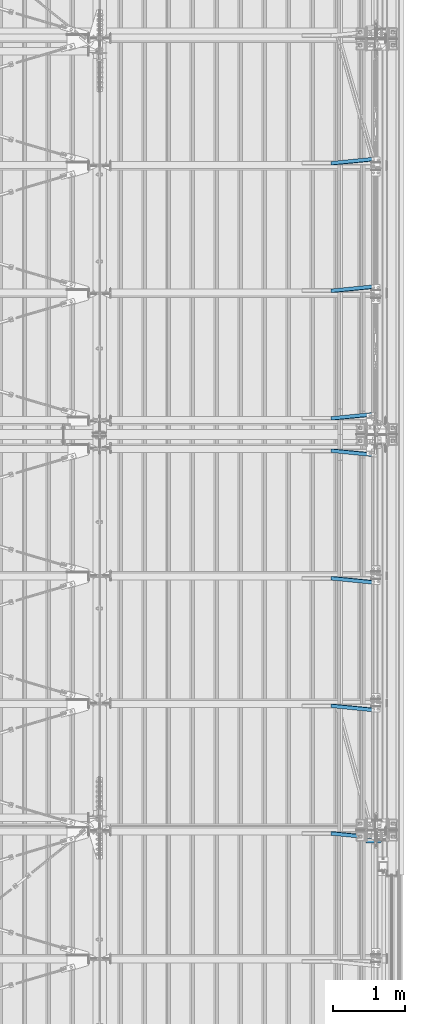
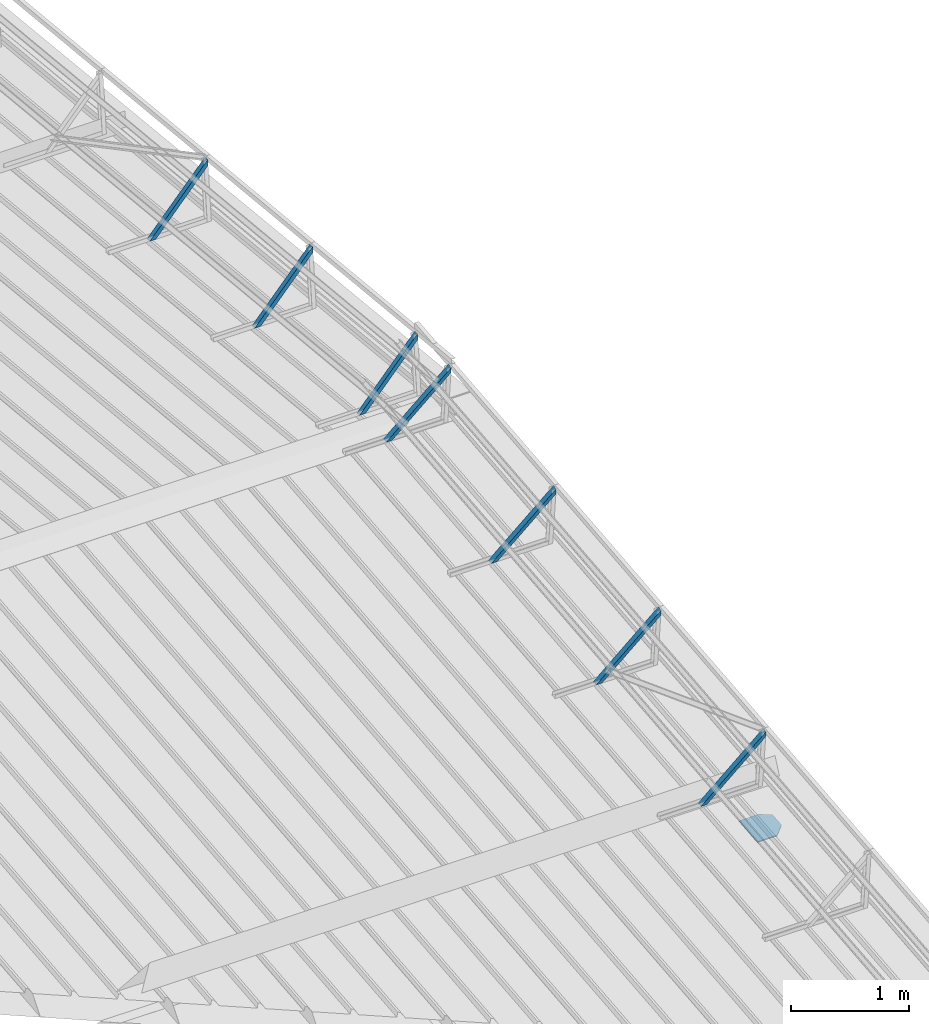
# One storey, part 318 of 709: 7 members, 1 beam, 8 elements without a shape of their own.
"""IFC4 building model written with IfcOpenShell, lengths in millimetres."""

from ifc_helpers import new_model, si_unit, direction, frame, origin_with_axes, place, context, subcontext, project, spatial, polygons, material, element, aggregate, save


model = new_model("IFC4")

# Units and contexts
model_context = context("Model", 3, precision=0.2, world=origin_with_axes(), true_north=direction((0.0, 1.0)))
body_context = subcontext(model_context, "Body", "Model", "MODEL_VIEW")
ifc_project = project(units=[si_unit("LENGTHUNIT", "METRE", prefix="MILLI"), si_unit("AREAUNIT", "SQUARE_METRE"), si_unit("VOLUMEUNIT", "CUBIC_METRE"), si_unit("MASSUNIT", "GRAM", prefix="KILO"), si_unit("TIMEUNIT", "SECOND"), si_unit("PLANEANGLEUNIT", "RADIAN"), si_unit("SOLIDANGLEUNIT", "STERADIAN"), si_unit("THERMODYNAMICTEMPERATUREUNIT", "DEGREE_CELSIUS"), si_unit("LUMINOUSINTENSITYUNIT", "LUMEN")], contexts=[model_context])

# Site, building, storey
site_placement = place(None, origin_with_axes())
site = spatial("IfcSite", under=ifc_project, at=site_placement, CompositionType="ELEMENT")
building_placement = place(site_placement, origin_with_axes())
building = spatial("IfcBuilding", under=site, at=building_placement, Name="Undefined", CompositionType="ELEMENT")
storey_placement = place(building_placement, origin_with_axes())
storey = spatial("IfcBuildingStorey", under=building, at=storey_placement, Name="Undefined", CompositionType="ELEMENT", Elevation=0.0)

# Assembly, beam
assembly_1_placement = place(storey_placement, frame((49851.0, 5500.0, -200.0), z_axis=(0.0, -1.0, 0.0), x_axis=(0.0, 0.0, 1.0)))
assembly_1 = element("IfcElementAssembly", 1, at=assembly_1_placement, inside=storey)
ifc_material_1 = material(Name="C355-6", Category="STEEL")
beam_placement = place(assembly_1_placement, frame((7746.45551, 0.0, 174.99876), z_axis=(0.9950371902, 0.0, 0.099503719), x_axis=(0.099503719, 0.0, -0.9950371902)))
beam = element("IfcBeam", 2, at=beam_placement, material=ifc_material_1, ObjectType="478", context=body_context, shape_type="Tessellation", body=[
    polygons([(0.0, -48.5, -6.0), (100.39404, -147.0, -6.0), (100.39404, -147.0, 6.0), (0.0, -48.5, 6.0), (0.0, 147.0, 6.0), (0.0, 147.0, -6.0), (309.74315, 147.0, 6.0), (309.74315, 147.0, -6.0), (309.74315, -48.5, 6.0), (309.74315, -48.5, -6.0), (250.13719, -147.0, -6.0), (250.13719, -147.0, 6.0)], [[[1, 2, 3, 4]], [[5, 6, 1, 4]], [[6, 5, 7, 8]], [[8, 7, 9, 10]], [[2, 1, 6, 8, 10, 11]], [[3, 2, 11, 12]], [[7, 5, 4, 3, 12, 9]], [[11, 10, 9, 12]]], closed=True),
])
aggregate(assembly_1, [beam])

# Assembly, member
assembly_2_placement = place(storey_placement, frame((49229.14214, 5456.63052, 8011.62024), z_axis=(0.7071067814, 0.0703597545, -0.7035975445), x_axis=(0.7071067814, -0.0703597545, 0.7035975445)))
assembly_2 = element("IfcElementAssembly", 3, at=assembly_2_placement, inside=storey)
ifc_material_2 = material(Name="Steel_Undefined", Category="STEEL")
member_1_placement = place(assembly_2_placement, origin_with_axes())
member_1 = element("IfcMember", 4, at=member_1_placement, material=ifc_material_2, ObjectType="603", context=body_context, shape_type="Tessellation", body=[
    polygons([(0.0, -25.0, -20.0), (0.0, 25.0, -20.0), (848.52814, 25.0, -20.0), (848.52814, -25.0, -20.0), (40.0, 25.0, 20.0), (808.52814, 25.0, 20.0), (40.0, 22.5, 20.0), (808.52814, 22.5, 20.0), (2.5, 22.5, -17.5), (846.02814, 22.5, -17.5), (2.5, -22.5, -17.5), (846.02814, -22.5, -17.5), (40.0, -22.5, 20.0), (808.52814, -22.5, 20.0), (40.0, -25.0, 20.0), (808.52814, -25.0, 20.0)], [[[1, 2, 3, 4]], [[2, 5, 6, 3]], [[5, 7, 8, 6]], [[7, 9, 10, 8]], [[9, 11, 12, 10]], [[11, 13, 14, 12]], [[13, 15, 16, 14]], [[15, 1, 4, 16]], [[6, 8, 10, 12, 14, 16, 4, 3]], [[15, 13, 11, 9, 7, 5, 2, 1]]], closed=True),
])
aggregate(assembly_2, [member_1])

assembly_3_placement = place(storey_placement, frame((49229.14214, 7229.93077, 8188.95027), z_axis=(0.7071067814, 0.0703597545, -0.7035975445), x_axis=(0.7071067814, -0.0703597545, 0.7035975445)))
assembly_3 = element("IfcElementAssembly", 5, at=assembly_3_placement, inside=storey)
member_2_placement = place(assembly_3_placement, origin_with_axes())
member_2 = element("IfcMember", 6, at=member_2_placement, material=ifc_material_2, ObjectType="603", context=body_context, shape_type="Tessellation", body=[
    polygons([(0.0, -25.0, -20.0), (0.0, 25.0, -20.0), (848.52814, 25.0, -20.0), (848.52814, -25.0, -20.0), (40.0, 25.0, 20.0), (808.52814, 25.0, 20.0), (40.0, 22.5, 20.0), (808.52814, 22.5, 20.0), (2.5, 22.5, -17.5), (846.02814, 22.5, -17.5), (2.5, -22.5, -17.5), (846.02814, -22.5, -17.5), (40.0, -22.5, 20.0), (808.52814, -22.5, 20.0), (40.0, -25.0, 20.0), (808.52814, -25.0, 20.0)], [[[1, 2, 3, 4]], [[2, 5, 6, 3]], [[5, 7, 8, 6]], [[7, 9, 10, 8]], [[9, 11, 12, 10]], [[11, 13, 14, 12]], [[13, 15, 16, 14]], [[15, 1, 4, 16]], [[6, 8, 10, 12, 14, 16, 4, 3]], [[15, 13, 11, 9, 7, 5, 2, 1]]], closed=True),
])
aggregate(assembly_3, [member_2])

assembly_4_placement = place(storey_placement, frame((49229.14214, 9003.23102, 8366.28029), z_axis=(0.7071067814, 0.0703597545, -0.7035975445), x_axis=(0.7071067814, -0.0703597545, 0.7035975445)))
assembly_4 = element("IfcElementAssembly", 7, at=assembly_4_placement, inside=storey)
member_3_placement = place(assembly_4_placement, origin_with_axes())
member_3 = element("IfcMember", 8, at=member_3_placement, material=ifc_material_2, ObjectType="603", context=body_context, shape_type="Tessellation", body=[
    polygons([(0.0, -25.0, -20.0), (0.0, 25.0, -20.0), (848.52814, 25.0, -20.0), (848.52814, -25.0, -20.0), (40.0, 25.0, 20.0), (808.52814, 25.0, 20.0), (40.0, 22.5, 20.0), (808.52814, 22.5, 20.0), (2.5, 22.5, -17.5), (846.02814, 22.5, -17.5), (2.5, -22.5, -17.5), (846.02814, -22.5, -17.5), (40.0, -22.5, 20.0), (808.52814, -22.5, 20.0), (40.0, -25.0, 20.0), (808.52814, -25.0, 20.0)], [[[1, 2, 3, 4]], [[2, 5, 6, 3]], [[5, 7, 8, 6]], [[7, 9, 10, 8]], [[9, 11, 12, 10]], [[11, 13, 14, 12]], [[13, 15, 16, 14]], [[15, 1, 4, 16]], [[6, 8, 10, 12, 14, 16, 4, 3]], [[15, 13, 11, 9, 7, 5, 2, 1]]], closed=True),
])
aggregate(assembly_4, [member_3])

assembly_5_placement = place(storey_placement, frame((49229.14214, 10776.53127, 8543.61032), z_axis=(0.7071067814, 0.0703597545, -0.7035975445), x_axis=(0.7071067814, -0.0703597545, 0.7035975445)))
assembly_5 = element("IfcElementAssembly", 9, at=assembly_5_placement, inside=storey)
member_4_placement = place(assembly_5_placement, origin_with_axes())
member_4 = element("IfcMember", 10, at=member_4_placement, material=ifc_material_2, ObjectType="603", context=body_context, shape_type="Tessellation", body=[
    polygons([(0.0, -25.0, -20.0), (0.0, 25.0, -20.0), (848.52814, 25.0, -20.0), (848.52814, -25.0, -20.0), (40.0, 25.0, 20.0), (808.52814, 25.0, 20.0), (40.0, 22.5, 20.0), (808.52814, 22.5, 20.0), (2.5, 22.5, -17.5), (846.02814, 22.5, -17.5), (2.5, -22.5, -17.5), (846.02814, -22.5, -17.5), (40.0, -22.5, 20.0), (808.52814, -22.5, 20.0), (40.0, -25.0, 20.0), (808.52814, -25.0, 20.0)], [[[1, 2, 3, 4]], [[2, 5, 6, 3]], [[5, 7, 8, 6]], [[7, 9, 10, 8]], [[9, 11, 12, 10]], [[11, 13, 14, 12]], [[13, 15, 16, 14]], [[15, 1, 4, 16]], [[6, 8, 10, 12, 14, 16, 4, 3]], [[15, 13, 11, 9, 7, 5, 2, 1]]], closed=True),
])
aggregate(assembly_5, [member_4])

assembly_6_placement = place(storey_placement, frame((49229.14214, 11223.46873, 8543.61032), z_axis=(0.7071067814, -0.0703597545, -0.7035975445), x_axis=(0.707106781, 0.070359754, 0.703597545)))
assembly_6 = element("IfcElementAssembly", 11, at=assembly_6_placement, inside=storey)
member_5_placement = place(assembly_6_placement, origin_with_axes())
member_5 = element("IfcMember", 12, at=member_5_placement, material=ifc_material_2, ObjectType="603", context=body_context, shape_type="Tessellation", body=[
    polygons([(0.0, -25.0, -20.0), (0.0, 25.0, -20.0), (848.52814, 25.0, -20.0), (848.52814, -25.0, -20.0), (40.0, 25.0, 20.0), (808.52814, 25.0, 20.0), (40.0, 22.5, 20.0), (808.52814, 22.5, 20.0), (2.5, 22.5, -17.5), (846.02814, 22.5, -17.5), (2.5, -22.5, -17.5), (846.02814, -22.5, -17.5), (40.0, -22.5, 20.0), (808.52814, -22.5, 20.0), (40.0, -25.0, 20.0), (808.52814, -25.0, 20.0)], [[[1, 2, 3, 4]], [[2, 5, 6, 3]], [[5, 7, 8, 6]], [[7, 9, 10, 8]], [[9, 11, 12, 10]], [[11, 13, 14, 12]], [[13, 15, 16, 14]], [[15, 1, 4, 16]], [[6, 8, 10, 12, 14, 16, 4, 3]], [[15, 13, 11, 9, 7, 5, 2, 1]]], closed=True),
])
aggregate(assembly_6, [member_5])

assembly_7_placement = place(storey_placement, frame((49229.14214, 12996.76898, 8366.28029), z_axis=(0.7071067814, -0.0703597545, -0.7035975445), x_axis=(0.707106781, 0.070359754, 0.703597545)))
assembly_7 = element("IfcElementAssembly", 13, at=assembly_7_placement, inside=storey)
member_6_placement = place(assembly_7_placement, origin_with_axes())
member_6 = element("IfcMember", 14, at=member_6_placement, material=ifc_material_2, ObjectType="603", context=body_context, shape_type="Tessellation", body=[
    polygons([(0.0, -25.0, -20.0), (0.0, 25.0, -20.0), (848.52814, 25.0, -20.0), (848.52814, -25.0, -20.0), (40.0, 25.0, 20.0), (808.52814, 25.0, 20.0), (40.0, 22.5, 20.0), (808.52814, 22.5, 20.0), (2.5, 22.5, -17.5), (846.02814, 22.5, -17.5), (2.5, -22.5, -17.5), (846.02814, -22.5, -17.5), (40.0, -22.5, 20.0), (808.52814, -22.5, 20.0), (40.0, -25.0, 20.0), (808.52814, -25.0, 20.0)], [[[1, 2, 3, 4]], [[2, 5, 6, 3]], [[5, 7, 8, 6]], [[7, 9, 10, 8]], [[9, 11, 12, 10]], [[11, 13, 14, 12]], [[13, 15, 16, 14]], [[15, 1, 4, 16]], [[6, 8, 10, 12, 14, 16, 4, 3]], [[15, 13, 11, 9, 7, 5, 2, 1]]], closed=True),
])
aggregate(assembly_7, [member_6])

assembly_8_placement = place(storey_placement, frame((49229.14214, 14770.06923, 8188.95027), z_axis=(0.7071067814, -0.0703597545, -0.7035975445), x_axis=(0.707106781, 0.070359754, 0.703597545)))
assembly_8 = element("IfcElementAssembly", 15, at=assembly_8_placement, inside=storey)
member_7_placement = place(assembly_8_placement, origin_with_axes())
member_7 = element("IfcMember", 16, at=member_7_placement, material=ifc_material_2, ObjectType="603", context=body_context, shape_type="Tessellation", body=[
    polygons([(0.0, -25.0, -20.0), (0.0, 25.0, -20.0), (848.52814, 25.0, -20.0), (848.52814, -25.0, -20.0), (40.0, 25.0, 20.0), (808.52814, 25.0, 20.0), (40.0, 22.5, 20.0), (808.52814, 22.5, 20.0), (2.5, 22.5, -17.5), (846.02814, 22.5, -17.5), (2.5, -22.5, -17.5), (846.02814, -22.5, -17.5), (40.0, -22.5, 20.0), (808.52814, -22.5, 20.0), (40.0, -25.0, 20.0), (808.52814, -25.0, 20.0)], [[[1, 2, 3, 4]], [[2, 5, 6, 3]], [[5, 7, 8, 6]], [[7, 9, 10, 8]], [[9, 11, 12, 10]], [[11, 13, 14, 12]], [[13, 15, 16, 14]], [[15, 1, 4, 16]], [[6, 8, 10, 12, 14, 16, 4, 3]], [[15, 13, 11, 9, 7, 5, 2, 1]]], closed=True),
])
aggregate(assembly_8, [member_7])

save(model, "model.ifc")
